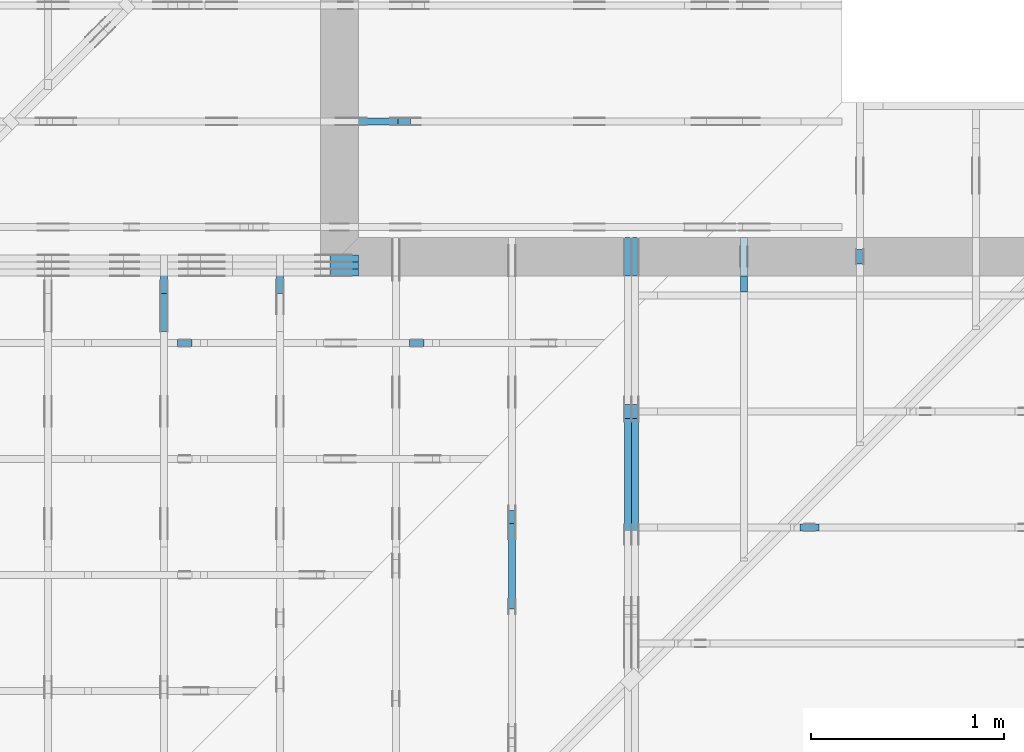
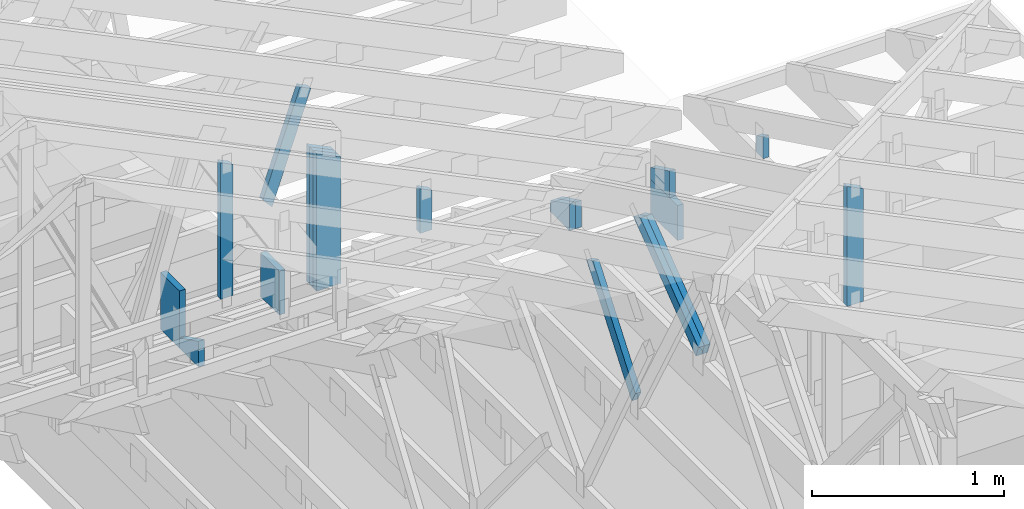
# One storey, part 50 of 159: 18 members, 10 elements without a shape of their own.
"""IFC2X3 building model written with IfcOpenShell, lengths in millimetres."""

from ifc_helpers import new_model, si_unit, frame, origin, origin_with_axes, origin_2d, place, context, project, spatial, faceted_brep, element, aggregate, save


model = new_model("IFC2X3")

# Units and contexts
model_context = context("Model", 3, precision=1e-05, world=origin())
plan_context = context("Plan", 2, precision=1e-05, world=origin_2d())
ifc_project = project(units=[si_unit("LENGTHUNIT", "METRE", prefix="MILLI"), si_unit("AREAUNIT", "SQUARE_METRE"), si_unit("VOLUMEUNIT", "CUBIC_METRE"), si_unit("SOLIDANGLEUNIT", "STERADIAN"), si_unit("PLANEANGLEUNIT", "RADIAN"), si_unit("MASSUNIT", "GRAM"), si_unit("TIMEUNIT", "SECOND"), si_unit("THERMODYNAMICTEMPERATUREUNIT", "DEGREE_CELSIUS"), si_unit("LUMINOUSINTENSITYUNIT", "LUMEN")], contexts=[model_context, plan_context])

# Site, building, storey
site_placement = place(None, origin_with_axes())
site = spatial("IfcSite", under=ifc_project, at=site_placement, CompositionType="ELEMENT")
building_placement = place(site_placement, origin_with_axes())
building = spatial("IfcBuilding", under=site, at=building_placement, Name="Plan 1", CompositionType="ELEMENT")
storey_placement = place(building_placement, origin_with_axes())
storey = spatial("IfcBuildingStorey", under=building, at=storey_placement, Name="Etasje 1", CompositionType="ELEMENT", Elevation=0.0)

# Assembly, members
assembly_1_placement = place(storey_placement, frame((10700.012663101485, 8801.999999990367, 0.0), z_axis=(0.0, -1.0, 6.123031769111886e-17), x_axis=(1.0, 0.0, 0.0)))
assembly_1 = element("IfcElementAssembly", 1, at=assembly_1_placement, inside=storey, Name="T8 (1)", AssemblyPlace="FACTORY", PredefinedType="TRUSS")
member_1_placement = place(assembly_1_placement, frame((5852.0, 1246.850830078125, -36.0), z_axis=(0.0, 0.0, 1.0), x_axis=(-1.836909530733566e-16, -1.0, 0.0)))
member_1 = element("IfcMember", 2, at=member_1_placement, Name="T8-S7", context=model_context, shape_type="Brep", body=[
    faceted_brep([(875.850830078125, 148.0, 36.0), (72.1844482421875, 148.0, 36.0), (0.0, 0.0, 36.0), (875.850830078125, 0.0, 36.0), (72.1844482421875, 148.0, 8.839753396454534e-15), (875.850830078125, 148.0, 1.0725724915142752e-13), (875.850830078125, 0.0, 1.0725724915142752e-13), (0.0, 0.0, 0.0), (2.2746622558770868e-05, 1.7741664121986508e-15, 2.4780981971831713e-31), (2.274662256075207e-05, 8.07867837839156e-16, 36.0), (72.18444585427645, 148.0, 36.0), (72.18444585427645, 148.0, -1.8327149350788936e-30), (875.8508300781257, -1.608858737271414e-13, 9.851093160326101e-30), (875.8508300781257, -1.5868158229026112e-13, 36.0), (2.2746622562408447e-05, 2.2042872585315014e-15, 36.0), (2.2746622562408447e-05, -4.178348777688724e-21, 2.5584162308217877e-37), (875.8508300781257, 148.0, 0.0), (875.8508300781257, 148.0, 36.0), (875.8508300781257, 0.0, 36.0), (875.8508300781257, 0.0, 0.0), (72.18444585427642, 148.0, 0.0), (72.18444585427642, 148.0, 36.0), (875.8508300781257, 147.99999999999994, 36.0), (875.8508300781257, 147.99999999999994, -3.1554436208840472e-30)], [[[0, 1, 2, 3]], [[4, 5, 6, 7]], [[8, 9, 10, 11]], [[12, 13, 14, 15]], [[16, 17, 18, 19]], [[20, 21, 22, 23]]]),
])
member_2_placement = place(assembly_1_placement, frame((5852.0, 1246.850830078125, -72.0), z_axis=(0.0, 0.0, 1.0), x_axis=(-1.836909530733566e-16, -1.0, 0.0)))
member_2 = element("IfcMember", 3, at=member_2_placement, Name="T8-S7", context=model_context, shape_type="Brep", body=[
    faceted_brep([(875.850830078125, 148.0, 36.0), (72.1844482421875, 148.0, 36.0), (0.0, 0.0, 36.0), (875.850830078125, 0.0, 36.0), (72.1844482421875, 148.0, 8.839753396454534e-15), (875.850830078125, 148.0, 1.0725724915142752e-13), (875.850830078125, 0.0, 1.0725724915142752e-13), (0.0, 0.0, 0.0), (2.2746622558770868e-05, 1.7741664121986508e-15, 2.4780981971831713e-31), (2.274662256075207e-05, 8.07867837839156e-16, 36.0), (72.18444585427645, 148.0, 36.0), (72.18444585427645, 148.0, -1.8327149350788936e-30), (875.8508300781257, -1.608858737271414e-13, 9.851093160326101e-30), (875.8508300781257, -1.5868158229026112e-13, 36.0), (2.2746622562408447e-05, 2.2042872585315014e-15, 36.0), (2.2746622562408447e-05, -4.178348777688724e-21, 2.5584162308217877e-37), (875.8508300781257, 148.0, 0.0), (875.8508300781257, 148.0, 36.0), (875.8508300781257, 0.0, 36.0), (875.8508300781257, 0.0, 0.0), (72.18444585427642, 148.0, 0.0), (72.18444585427642, 148.0, 36.0), (875.8508300781257, 147.99999999999994, 36.0), (875.8508300781257, 147.99999999999994, -3.1554436208840472e-30)], [[[0, 1, 2, 3]], [[4, 5, 6, 7]], [[8, 9, 10, 11]], [[12, 13, 14, 15]], [[16, 17, 18, 19]], [[20, 21, 22, 23]]]),
])
member_3_placement = place(assembly_1_placement, frame((5852.0, 1246.850830078125, -108.0), z_axis=(0.0, 0.0, 1.0), x_axis=(-1.836909530733566e-16, -1.0, 0.0)))
member_3 = element("IfcMember", 4, at=member_3_placement, Name="T8-S7", context=model_context, shape_type="Brep", body=[
    faceted_brep([(875.850830078125, 148.0, 36.0), (72.1844482421875, 148.0, 36.0), (0.0, 0.0, 36.0), (875.850830078125, 0.0, 36.0), (72.1844482421875, 148.0, 8.839753396454534e-15), (875.850830078125, 148.0, 1.0725724915142752e-13), (875.850830078125, 0.0, 1.0725724915142752e-13), (0.0, 0.0, 0.0), (2.2746622558770868e-05, 1.7741664121986508e-15, 2.4780981971831713e-31), (2.274662256075207e-05, 8.07867837839156e-16, 36.0), (72.18444585427645, 148.0, 36.0), (72.18444585427645, 148.0, -1.8327149350788936e-30), (875.8508300781257, -1.608858737271414e-13, 9.851093160326101e-30), (875.8508300781257, -1.5868158229026112e-13, 36.0), (2.2746622562408447e-05, 2.2042872585315014e-15, 36.0), (2.2746622562408447e-05, -4.178348777688724e-21, 2.5584162308217877e-37), (875.8508300781257, 148.0, 0.0), (875.8508300781257, 148.0, 36.0), (875.8508300781257, 0.0, 36.0), (875.8508300781257, 0.0, 0.0), (72.18444585427642, 148.0, 0.0), (72.18444585427642, 148.0, 36.0), (875.8508300781257, 147.99999999999994, 36.0), (875.8508300781257, 147.99999999999994, -3.1554436208840472e-30)], [[[0, 1, 2, 3]], [[4, 5, 6, 7]], [[8, 9, 10, 11]], [[12, 13, 14, 15]], [[16, 17, 18, 19]], [[20, 21, 22, 23]]]),
])
aggregate(assembly_1, [member_1, member_2, member_3])

# Assembly, member
assembly_2_placement = place(storey_placement, frame((19200.01266310149, 9617.999978540158, 1.1021457184401395e-15), z_axis=(1.2246063538223773e-16, 1.0, 6.123031769111886e-17), x_axis=(-1.0, 1.2246063538223773e-16, 0.0)))
assembly_2 = element("IfcElementAssembly", 5, at=assembly_2_placement, inside=storey, Name="V12 (104)", AssemblyPlace="FACTORY", PredefinedType="TRUSS")
member_4_placement = place(assembly_2_placement, frame((2228.9607302799177, 1052.1593241434744, -36.0), z_axis=(0.0, 0.0, 1.0), x_axis=(0.32803674405309335, -0.9446649641809763, 0.0)))
member_4 = element("IfcMember", 6, at=member_4_placement, Name="V12-D66", context=model_context, shape_type="Brep", body=[
    faceted_brep([(681.0706110310787, 72.99994068345177, 36.0), (8.410677298797964e-05, 72.99994068345177, 36.0), (8.769760310429888, 0.00011918098152818857, 36.0), (721.0591585070997, 0.00011918098152818857, 36.0), (8.410677298797964e-05, 72.99994068345177, 1.0299768860057616e-20), (681.0706110310787, 72.99994068345177, 8.340433976703478e-14), (721.0591585070997, 0.00011918098152818857, 8.83013626989611e-14), (8.769760310429888, 0.00011918098152818857, 1.0739504197651744e-15), (8.769783254570372, 2.2695207917422522e-05, 0.0), (8.769783254570376, 2.2695207917644566e-05, 36.0), (2.3092638912203256e-14, 73.00002269520702, 36.0), (2.1316282072803006e-14, 73.00002269520702, -1.3805065841367707e-30), (721.0591663880548, 2.2695208419800768e-05, -2.9164548988533967e-30), (721.0591663880548, 2.269520842200506e-05, 36.0), (8.76978325457037, 2.2695207920206116e-05, 36.0), (8.76978325457037, 2.2695207918001825e-05, -3.547096521402882e-32), (681.070651999221, 73.00002269520658, -5.4998942480018194e-30), (681.070651999221, 73.00002269520658, 36.0), (721.0591663880548, 2.2695208372169873e-05, 36.0), (721.0591663880548, 2.2695208372169873e-05, -5.243406304481854e-30), (0.0, 73.00002269520701, 0.0), (0.0, 73.00002269520701, 36.0), (681.0706519992211, 73.00002269520651, 36.0), (681.0706519992211, 73.00002269520651, -2.3665827156630354e-30)], [[[0, 1, 2, 3]], [[4, 5, 6, 7]], [[8, 9, 10, 11]], [[12, 13, 14, 15]], [[16, 17, 18, 19]], [[20, 21, 22, 23]]]),
])
aggregate(assembly_2, [member_4])

assembly_3_placement = place(storey_placement, frame((16311.022261404749, -699.9989301294839, 1.1021457184401395e-15), z_axis=(1.0, -6.123031769111886e-17, 6.123031769111886e-17), x_axis=(6.123031769111886e-17, 1.0, 0.0)))
assembly_3 = element("IfcElementAssembly", 7, at=assembly_3_placement, inside=storey, Name="V8 (33)", AssemblyPlace="FACTORY", PredefinedType="TRUSS")
member_5_placement = place(assembly_3_placement, frame((9609.9990234375, 370.9999999999935, -36.0), z_axis=(0.0, 0.0, 1.0), x_axis=(3.270178724167072e-14, 1.0, 0.0)))
member_5 = element("IfcMember", 8, at=member_5_placement, Name="V8-S3", context=model_context, shape_type="Brep", body=[
    faceted_brep([(278.47998046874994, 198.0000000000091, 36.0), (0.0, 198.0000000000091, 36.0), (6.480149750132114e-12, 0.0, 36.0), (278.4799804687564, 0.0, 36.0), (0.0, 198.0000000000091, 0.0), (278.47998046874994, 198.0000000000091, 3.410283534943627e-14), (278.4799804687564, 0.0, 3.4102835349437066e-14), (6.480149750132114e-12, 0.0, 7.935632557732277e-28), (6.480149790444615e-12, 9.332086483482271e-05, -2.4683472462447996e-36), (6.482354081881495e-12, 9.332086483482271e-05, 36.0), (8.773584851484226e-14, 198.00009332085028, 36.0), (8.553155707796198e-14, 198.00009332085028, -5.237124412499736e-30), (278.48000000045346, 9.331853113146364e-05, -3.676616062479308e-30), (278.48000000045346, 9.331853113366793e-05, 36.0), (6.480149750132132e-12, 9.3320864837027e-05, 36.0), (6.480149750132114e-12, 9.332086483482271e-05, 0.0), (278.48000000045346, 198.00009331853107, 3.9758589623138995e-28), (278.48000000045346, 198.00009331853107, 36.0), (278.48000000045346, 9.331853107141796e-05, 36.0), (278.48000000045346, 9.331853107141796e-05, 0.0), (0.0, 198.00009332085028, 0.0), (0.0, 198.00009332085028, 36.0), (278.480000000447, 198.00009331853107, 36.0), (278.480000000447, 198.00009331853107, 0.0)], [[[0, 1, 2, 3]], [[4, 5, 6, 7]], [[8, 9, 10, 11]], [[12, 13, 14, 15]], [[16, 17, 18, 19]], [[20, 21, 22, 23]]]),
])
aggregate(assembly_3, [member_5])

# Assembly, members
assembly_4_placement = place(storey_placement, frame((18074.541652722903, -699.9989301294845, 4.408582873760558e-15), z_axis=(-1.0, 1.836909530733566e-16, 6.123031769111886e-17), x_axis=(-1.836909530733566e-16, -1.0, 0.0)))
assembly_4 = element("IfcElementAssembly", 9, at=assembly_4_placement, inside=storey, Name="V5 (30)", AssemblyPlace="FACTORY", PredefinedType="TRUSS")
member_6_placement = place(assembly_4_placement, frame((-9501.998923972249, 222.99999999999997, -36.0), z_axis=(0.0, 0.0, 1.0), x_axis=(6.123031769111886e-17, 1.0, 0.0)))
member_6 = element("IfcMember", 10, at=member_6_placement, Name="V5-S4", context=model_context, shape_type="Brep", body=[
    faceted_brep([(73.74774169921878, 198.00009946525097, 36.0), (0.0, 198.00009946525097, 36.0), (2.842170943040401e-14, 9.94652509689331e-05, 36.0), (170.31878662109378, 9.94652509689331e-05, 36.0), (0.0, 198.00009946525097, 0.0), (73.74774169921878, 198.00009946525097, 9.03119530649148e-15), (170.31878662109378, 9.94652509689331e-05, 2.0857346827150914e-14), (2.842170943040401e-14, 9.94652509689331e-05, 3.4805405954966126e-30), (1.1937117960769683e-12, 0.0, 0.0), (1.1959160875138486e-12, -2.6993892992798474e-31, 36.0), (1.2201632933197599e-12, 198.00000000186265, 36.0), (1.2179590018828796e-12, 198.00000000186265, -1.4846641146178842e-30), (170.31878034491095, 1.8625988906436828e-09, 2.832427994748259e-30), (170.31878034491095, 1.8626010949351197e-09, 36.0), (1.1937117960769443e-12, 2.204291436879955e-15, 36.0), (1.1937117960769683e-12, -3.2421216959835216e-28, 1.9851614143888933e-44), (73.74772780854258, 198.00000000186265, -1.5777218104420236e-30), (73.74772780854258, 198.00000000186265, 36.0), (170.31878034491098, 1.8626593600856722e-09, 36.0), (170.31878034491098, 1.8626593600856722e-09, 0.0), (1.1937117960769683e-12, 198.00000000186265, 0.0), (1.1937117960769683e-12, 198.00000000186265, 36.0), (73.74772780854258, 198.00000000186265, 36.0), (73.74772780854258, 198.00000000186265, 0.0)], [[[0, 1, 2, 3]], [[4, 5, 6, 7]], [[8, 9, 10, 11]], [[12, 13, 14, 15]], [[16, 17, 18, 19]], [[20, 21, 22, 23]]]),
])
member_7_placement = place(assembly_4_placement, frame((-9501.998923972249, 222.99999999999997, -72.0), z_axis=(0.0, 0.0, 1.0), x_axis=(6.123031769111886e-17, 1.0, 0.0)))
member_7 = element("IfcMember", 11, at=member_7_placement, Name="V5-S4", context=model_context, shape_type="Brep", body=[
    faceted_brep([(73.74774169921878, 198.00009946525097, 36.0), (0.0, 198.00009946525097, 36.0), (2.842170943040401e-14, 9.94652509689331e-05, 36.0), (170.31878662109378, 9.94652509689331e-05, 36.0), (0.0, 198.00009946525097, 0.0), (73.74774169921878, 198.00009946525097, 9.03119530649148e-15), (170.31878662109378, 9.94652509689331e-05, 2.0857346827150914e-14), (2.842170943040401e-14, 9.94652509689331e-05, 3.4805405954966126e-30), (1.1937117960769683e-12, 0.0, 0.0), (1.1959160875138486e-12, -2.6993892992798474e-31, 36.0), (1.2201632933197599e-12, 198.00000000186265, 36.0), (1.2179590018828796e-12, 198.00000000186265, -1.4846641146178842e-30), (170.31878034491095, 1.8625988906436828e-09, 2.832427994748259e-30), (170.31878034491095, 1.8626010949351197e-09, 36.0), (1.1937117960769443e-12, 2.204291436879955e-15, 36.0), (1.1937117960769683e-12, -3.2421216959835216e-28, 1.9851614143888933e-44), (73.74772780854258, 198.00000000186265, -1.5777218104420236e-30), (73.74772780854258, 198.00000000186265, 36.0), (170.31878034491098, 1.8626593600856722e-09, 36.0), (170.31878034491098, 1.8626593600856722e-09, 0.0), (1.1937117960769683e-12, 198.00000000186265, 0.0), (1.1937117960769683e-12, 198.00000000186265, 36.0), (73.74772780854258, 198.00000000186265, 36.0), (73.74772780854258, 198.00000000186265, 0.0)], [[[0, 1, 2, 3]], [[4, 5, 6, 7]], [[8, 9, 10, 11]], [[12, 13, 14, 15]], [[16, 17, 18, 19]], [[20, 21, 22, 23]]]),
])
member_8_placement = place(assembly_4_placement, frame((-8837.338970727391, 717.4950314596726, -36.0), z_axis=(0.0, 0.0, 1.0), x_axis=(0.7964129491034229, -0.6047531847790376, 0.0)))
member_8 = element("IfcMember", 12, at=member_8_placement, Name="V5-D60", context=model_context, shape_type="Brep", body=[
    faceted_brep([(796.6997639617321, 73.00006327458777, 36.0), (36.85758525912206, 73.00006327458777, 36.0), (3.061633378820261e-05, 0.00013089083131490042, 36.0), (817.6807396894483, 0.00013089083131490042, 36.0), (36.85758525912206, 73.00006327458777, 4.5136033094870866e-15), (796.6997639617321, 73.00006327458777, 9.756435930363253e-14), (817.6807396894483, 0.00013089083131490042, 1.0013370292218797e-13), (3.061633378820261e-05, 0.00013089083131490042, 3.749295688777965e-21), (2.095722141833012e-15, 0.00013639759072142315, -1.4375035780612495e-31), (4.063433888413376e-15, 0.00013639759072042967, 36.0), (36.85723078302818, 73.00013639759162, 36.0), (36.85723078302818, 73.00013639759162, -7.358978317503628e-31), (817.68091931447, 0.00013639758548855484, 4.203172982901901e-29), (817.68091931447, 0.00013639758549075914, 36.0), (1.4109555365575329e-29, 0.00013639759072468555, 36.0), (0.0, 0.00013639759072248125, 0.0), (796.6998592314928, 73.00013639758708, -1.262177448353619e-29), (796.6998592314928, 73.00013639758708, 36.0), (817.6809193144697, 0.00013639758614658604, 36.0), (817.6809193144697, 0.00013639758614658604, -1.262177448353619e-29), (36.85723078302817, 73.00013639759163, 0.0), (36.85723078302817, 73.00013639759163, 36.0), (796.6998592314931, 73.00013639758703, 36.0), (796.6998592314931, 73.00013639758703, -3.944304526105059e-30)], [[[0, 1, 2, 3]], [[4, 5, 6, 7]], [[8, 9, 10, 11]], [[12, 13, 14, 15]], [[16, 17, 18, 19]], [[20, 21, 22, 23]]]),
])
member_9_placement = place(assembly_4_placement, frame((-8837.338970727391, 717.4950314596726, -72.0), z_axis=(0.0, 0.0, 1.0), x_axis=(0.7964129491034229, -0.6047531847790376, 0.0)))
member_9 = element("IfcMember", 13, at=member_9_placement, Name="V5-D60", context=model_context, shape_type="Brep", body=[
    faceted_brep([(796.6997639617321, 73.00006327458777, 36.0), (36.85758525912206, 73.00006327458777, 36.0), (3.061633378820261e-05, 0.00013089083131490042, 36.0), (817.6807396894483, 0.00013089083131490042, 36.0), (36.85758525912206, 73.00006327458777, 4.5136033094870866e-15), (796.6997639617321, 73.00006327458777, 9.756435930363253e-14), (817.6807396894483, 0.00013089083131490042, 1.0013370292218797e-13), (3.061633378820261e-05, 0.00013089083131490042, 3.749295688777965e-21), (2.095722141833012e-15, 0.00013639759072142315, -1.4375035780612495e-31), (4.063433888413376e-15, 0.00013639759072042967, 36.0), (36.85723078302818, 73.00013639759162, 36.0), (36.85723078302818, 73.00013639759162, -7.358978317503628e-31), (817.68091931447, 0.00013639758548855484, 4.203172982901901e-29), (817.68091931447, 0.00013639758549075914, 36.0), (1.4109555365575329e-29, 0.00013639759072468555, 36.0), (0.0, 0.00013639759072248125, 0.0), (796.6998592314928, 73.00013639758708, -1.262177448353619e-29), (796.6998592314928, 73.00013639758708, 36.0), (817.6809193144697, 0.00013639758614658604, 36.0), (817.6809193144697, 0.00013639758614658604, -1.262177448353619e-29), (36.85723078302817, 73.00013639759163, 0.0), (36.85723078302817, 73.00013639759163, 36.0), (796.6998592314931, 73.00013639758703, 36.0), (796.6998592314931, 73.00013639758703, -3.944304526105059e-30)], [[[0, 1, 2, 3]], [[4, 5, 6, 7]], [[8, 9, 10, 11]], [[12, 13, 14, 15]], [[16, 17, 18, 19]], [[20, 21, 22, 23]]]),
])
aggregate(assembly_4, [member_6, member_7, member_8, member_9])

# Assembly, member
assembly_5_placement = place(storey_placement, frame((17475.02226140475, -699.9989301294827, 1.1021457184401395e-15), z_axis=(-1.0, 1.836909530733566e-16, 6.123031769111886e-17), x_axis=(-1.836909530733566e-16, -1.0, 0.0)))
assembly_5 = element("IfcElementAssembly", 14, at=assembly_5_placement, inside=storey, Name="V6 (31)", AssemblyPlace="FACTORY", PredefinedType="TRUSS")
member_10_placement = place(assembly_5_placement, frame((-8287.689453125002, 985.5772705078125, -36.0), z_axis=(0.0, 0.0, 1.0), x_axis=(0.6077192601701953, -0.7941519381190167, 0.0)))
member_10 = element("IfcMember", 15, at=member_10_placement, Name="V6-D62", context=model_context, shape_type="Brep", body=[
    faceted_brep([(742.2078949296147, 73.00027635544029, 36.0), (14.75236930580104, 73.00027635544029, 36.0), (0.0, 0.0, 36.0), (773.8788700743089, 0.0, 36.0), (14.75236930580104, 73.00027635544029, 1.8065845185818165e-15), (742.2078949296147, 73.00027635544029, 9.089125039879376e-14), (773.8788700743089, 0.0, 9.476969813818806e-14), (0.0, 0.0, 0.0), (0.00022540169811499373, 0.00025948535494574223, 1.198048796030385e-31), (0.00022540169811715436, 0.0002594853549453056, 36.0), (14.752456127954233, 73.00025948535314, 36.0), (14.75245612795423, 73.00025948535314, 1.05511620613424e-30), (773.8788998711179, 0.00025948535549054233, 2.2306635200299982e-29), (773.8788998711179, 0.0002594853554927466, 36.0), (0.0002254016981169116, 0.0002594853549475588, 36.0), (0.0002254016981169116, 0.0002594853549453545, 9.027796614315168e-36), (742.2078817748177, 73.00025948535395, -1.1917857587796813e-29), (742.2078817748177, 73.00025948535395, 36.0), (773.8788998711177, 0.0002594853557980059, 36.0), (773.8788998711177, 0.0002594853557980059, -1.1672650650887484e-29), (14.752456127954247, 73.00025948535313, 0.0), (14.752456127954247, 73.00025948535313, 36.0), (742.2078817748179, 73.00025948535405, 36.0), (742.2078817748179, 73.00025948535405, 7.888609052210118e-31)], [[[0, 1, 2, 3]], [[4, 5, 6, 7]], [[8, 9, 10, 11]], [[12, 13, 14, 15]], [[16, 17, 18, 19]], [[20, 21, 22, 23]]]),
])
aggregate(assembly_5, [member_10])

assembly_6_placement = place(storey_placement, frame((19275.02226140475, 9699.999999999993, 1.1021457184401395e-15), z_axis=(-1.0, 1.836909530733566e-16, 6.123031769111886e-17), x_axis=(-1.836909530733566e-16, -1.0, 0.0)))
assembly_6 = element("IfcElementAssembly", 16, at=assembly_6_placement, inside=storey, Name="S23 (56)", AssemblyPlace="FACTORY", PredefinedType="TRUSS")
member_11_placement = place(assembly_6_placement, frame((762.5, 362.835490555932, -36.0), z_axis=(0.0, 0.0, 1.0), x_axis=(-1.836909530733566e-16, -1.0, 0.0)))
member_11 = element("IfcMember", 17, at=member_11_placement, Name="S23-D72", context=model_context, shape_type="Brep", body=[
    faceted_brep([(139.83549055593195, 73.00000000000011, 36.0), (1.0819603801337507e-05, 73.00000000000011, 36.0), (35.60447248952573, 0.0, 36.0), (139.83549055593195, 0.0, 36.0), (1.0819603801337507e-05, 73.00000000000011, 1.3249755560958657e-21), (139.83549055593195, 73.00000000000011, 1.712434302246633e-14), (139.83549055593195, 0.0, 1.712434302246633e-14), (35.60447248952573, 0.0, 4.360146323516725e-15), (35.60447896533474, -1.7763568394002505e-15, 3.4633466240401087e-31), (35.60447896533475, 0.0, 36.0), (3.552713678800501e-15, 73.00000000000001, 36.0), (0.0, 73.00000000000001, -1.922479744743257e-31), (139.83549055593195, 5.967783702884803e-14, 3.3069882705980434e-30), (139.83549055593195, 6.188212846572831e-14, 36.0), (35.60447896533475, -1.1547312833676879e-14, 36.0), (35.60447896533475, -1.3751604270557158e-14, 8.420150982487615e-31), (139.83549055593195, 73.00000000000011, 0.0), (139.83549055593195, 73.00000000000011, 36.0), (139.83549055593195, 1.1368683772161603e-13, 36.0), (139.83549055593195, 1.1368683772161603e-13, 0.0), (0.0, 73.0, 0.0), (0.0, 73.0, 36.0), (139.83549055593195, 73.00000000000014, 36.0), (139.83549055593195, 73.00000000000014, 1.5777218104420236e-30)], [[[0, 1, 2, 3]], [[4, 5, 6, 7]], [[8, 9, 10, 11]], [[12, 13, 14, 15]], [[16, 17, 18, 19]], [[20, 21, 22, 23]]]),
])
aggregate(assembly_6, [member_11])

# Assembly, members
assembly_7_placement = place(storey_placement, frame((18675.02226140475, 8999.999999999993, 1.1021457184401395e-15), z_axis=(-1.0, 1.836909530733566e-16, 6.123031769111886e-17), x_axis=(-1.836909530733566e-16, -1.0, 0.0)))
assembly_7 = element("IfcElementAssembly", 18, at=assembly_7_placement, inside=storey, Name="S25 (55)", AssemblyPlace="FACTORY", PredefinedType="TRUSS")
member_12_placement = place(assembly_7_placement, frame((198.00000000186265, 222.9999999999992, -36.0), z_axis=(0.0, 0.0, 1.0), x_axis=(6.123031769111886e-17, 1.0, 0.0)))
member_12 = element("IfcMember", 19, at=member_12_placement, Name="S25-S4", context=model_context, shape_type="Brep", body=[
    faceted_brep([(73.74771118164142, 198.00000000186267, 36.0), (7.958078640513122e-13, 198.00000000186267, 36.0), (7.958078640513122e-13, 1.862645149230957e-09, 36.0), (170.31878662109455, 1.862645149230957e-09, 36.0), (7.958078640513122e-13, 198.00000000186267, 9.745513667390515e-29), (73.74771118164142, 198.00000000186267, 9.031191569289567e-15), (170.31878662109455, 1.862645149230957e-09, 2.085734682715101e-14), (7.958078640513122e-13, 1.862645149230957e-09, 9.745513667390515e-29), (0.0, 0.0, 0.0), (2.204291436880279e-15, -9.080057312278785e-30, 36.0), (8.178184691953749e-13, 198.0, 36.0), (8.156141777584947e-13, 198.0, 5.275234171675631e-31), (170.31877734232773, 1.8627501312700795e-09, -4.687813309593267e-30), (170.31877734232773, 1.8627523355615164e-09, 36.0), (-2.4107994593886833e-26, 2.204291436880279e-15, 36.0), (0.0, 0.0, 0.0), (73.7477248059594, 198.0000000018627, 1.5777218104420236e-30), (73.7477248059594, 198.0000000018627, 36.0), (170.3187773423278, 1.8626877817951026e-09, 36.0), (170.3187773423278, 1.8626877817951026e-09, 3.1554436208840472e-30), (8.242295734817162e-13, 198.0, 0.0), (8.242295734817162e-13, 198.0, 36.0), (73.74772480595936, 198.00000000186267, 36.0), (73.74772480595936, 198.00000000186267, 0.0)], [[[0, 1, 2, 3]], [[4, 5, 6, 7]], [[8, 9, 10, 11]], [[12, 13, 14, 15]], [[16, 17, 18, 19]], [[20, 21, 22, 23]]]),
])
member_13_placement = place(assembly_7_placement, frame((282.00633155073683, 223.0, -36.0), z_axis=(0.0, 0.0, 1.0), x_axis=(-1.0, 4.119263524032801e-15, 0.0)))
member_13 = element("IfcMember", 20, at=member_13_placement, Name="S25-U31", context=model_context, shape_type="Brep", body=[
    faceted_brep([(282.0063315507359, 223.00000000000117, 36.0), (1.4412064047064632e-05, 223.00000000000117, 36.0), (1.4412064956559334e-05, 0.0, 36.0), (282.00633155073683, 0.0, 36.0), (1.4412064047064632e-05, 223.00000000000117, 1.7649105203730393e-21), (282.0063315507359, 223.00000000000117, 3.4534674543517114e-14), (282.00633155073683, 0.0, 3.453467454351723e-14), (1.4412064956559334e-05, 0.0, 1.7649106317503384e-21), (9.094947017729282e-13, 0.0, 0.0), (9.116989932098085e-13, 8.540179452422816e-30, 36.0), (4.772067073097186e-14, 223.0, 36.0), (4.551637929409158e-14, 223.0, -2.786982364326692e-30), (282.00633155073683, 1.2005576776955354e-12, -2.159445804128965e-30), (282.00633155073683, 1.2027619691324157e-12, 36.0), (9.094947017729282e-13, 2.2042914368803927e-15, 36.0), (9.094947017729282e-13, 1.1374101789470858e-28, -6.964398660204246e-45), (282.00633155073683, 223.00000000000117, 5.679798517591285e-29), (282.00633155073683, 223.00000000000117, 36.0), (282.00633155073683, 1.1652900866465643e-12, 36.0), (282.00633155073683, 1.1652900866465643e-12, 0.0), (0.0, 223.0, 0.0), (0.0, 223.0, 36.0), (282.0063315507359, 223.00000000000117, 36.0), (282.0063315507359, 223.00000000000117, 1.5777218104420236e-30)], [[[0, 1, 2, 3]], [[4, 5, 6, 7]], [[8, 9, 10, 11]], [[12, 13, 14, 15]], [[16, 17, 18, 19]], [[20, 21, 22, 23]]]),
])
aggregate(assembly_7, [member_12, member_13])

# Assembly, member
assembly_8_placement = place(storey_placement, frame((21100.012663101486, 7517.993668449257, 1.1021457184401395e-15), z_axis=(1.2246063538223773e-16, 1.0, 6.123031769111886e-17), x_axis=(-1.0, 1.2246063538223773e-16, 0.0)))
assembly_8 = element("IfcElementAssembly", 21, at=assembly_8_placement, inside=storey, Name="S18 (46)", AssemblyPlace="FACTORY", PredefinedType="TRUSS")
member_14_placement = place(assembly_8_placement, frame((2019.0946044921875, 987.9109634286215, -36.0), z_axis=(0.0, 0.0, 1.0), x_axis=(-1.836909530733566e-16, -1.0, 0.0)))
member_14 = element("IfcMember", 22, at=member_14_placement, Name="S18-S11", context=model_context, shape_type="Brep", body=[
    faceted_brep([(764.9109634286215, 98.00012207031273, 36.0), (1.3721590221393853e-05, 98.00012207031273, 36.0), (47.79780424893397, 0.0, 36.0), (764.9109634286215, 0.0, 36.0), (1.3721590221393853e-05, 98.00012207031273, 1.6803546569665913e-21), (764.9109634286215, 98.00012207031273, 9.367148259230859e-14), (764.9109634286215, 0.0, 9.367148259230859e-14), (47.79780424893397, 0.0, 5.8533494782002766e-15), (47.797793679405, 3.8814963776445666e-05, -3.944304526105059e-31), (47.797793679405004, 3.8814963776445666e-05, 36.0), (2.1316282072803006e-14, 98.00003881496401, 36.0), (2.1316282072803006e-14, 98.00003881496401, -1.9721522630525295e-30), (764.9109634292258, 3.881496361723058e-05, 2.3453419277097786e-29), (764.9109634292258, 3.881496361943487e-05, 36.0), (47.797793679405004, 3.8814963751162064e-05, 36.0), (47.797793679405004, 3.881496374895777e-05, 1.4655582083566184e-30), (764.9109634292258, 98.000038814964, 3.74235613436848e-27), (764.9109634292258, 98.000038814964, 36.0), (764.9109634292258, 3.881496400026663e-05, 36.0), (764.9109634292258, 3.881496400026663e-05, 0.0), (0.0, 98.000038814964, 0.0), (-1.3496946496399237e-31, 98.000038814964, 36.0), (764.9109634291648, 98.00003881496396, 36.0), (764.9109634291648, 98.00003881496396, -3.1554436208840472e-30)], [[[0, 1, 2, 3]], [[4, 5, 6, 7]], [[8, 9, 10, 11]], [[12, 13, 14, 15]], [[16, 17, 18, 19]], [[20, 21, 22, 23]]]),
])
aggregate(assembly_8, [member_14])

# Assembly, members
assembly_9_placement = place(storey_placement, frame((11246.01259527543, 8436.00006782605, 727.7147722720857), z_axis=(0.0, -1.0, 6.123031769111886e-17), x_axis=(1.0, 0.0, 0.0)))
assembly_9 = element("IfcElementAssembly", 23, at=assembly_9_placement, inside=storey, Name="Tr1 (1)", AssemblyPlace="FACTORY", PredefinedType="TRUSS")
member_15_placement = place(assembly_9_placement, frame((4590.500067826054, 89.22082903113537, -36.0), z_axis=(0.0, 0.0, 1.0), x_axis=(6.123031769111886e-17, 1.0, 0.0)))
member_15 = element("IfcMember", 24, at=member_15_placement, Name="Tr1-D58", context=model_context, shape_type="Brep", body=[
    faceted_brep([(870.1224326876146, 73.00006782605396, 36.0), (3.793571650589911e-06, 73.00006782605396, 36.0), (3.7935716648007656e-06, 6.782605396438157e-05, 36.0), (834.5179405001146, 6.782605396438157e-05, 36.0), (3.793571650589911e-06, 73.00006782605396, 4.645631946992848e-22), (870.1224326876146, 73.00006782605396, 1.0655574596726366e-13), (834.5179405001146, 6.782605396438157e-05, 1.0219559723152049e-13), (3.7935716648007656e-06, 6.782605396438157e-05, 4.645631964395551e-22), (1.0729195309977514e-11, 1.8367099231598242e-40, -8.96831017167883e-44), (1.0731399601414395e-11, 3.2374663713226847e-28, 36.0), (9.81165019023506e-15, 73.0, 36.0), (7.607358753354782e-15, 73.0, -4.65800993258218e-31), (834.5179701715656, -1.5329340129765785e-13, 9.386203661407763e-30), (834.5179701715656, -1.5108910986077757e-13, 36.0), (1.0729195309977513e-11, 2.204291436878308e-15, 36.0), (1.0729195309977513e-11, -1.970856112199957e-27, 1.2067614587348676e-43), (870.1224491368732, 73.00000000000006, -7.688461917283971e-30), (870.1224491368732, 73.00000000000006, 36.0), (834.5179701715656, 0.0, 36.0), (834.5179701715656, 0.0, -7.438183648941331e-30), (0.0, 73.0, 0.0), (-1.3496946496399237e-31, 73.0, 36.0), (870.1224491368731, 72.99999999999994, 36.0), (870.1224491368731, 72.99999999999994, -3.1554436208840472e-30)], [[[0, 1, 2, 3]], [[4, 5, 6, 7]], [[8, 9, 10, 11]], [[12, 13, 14, 15]], [[16, 17, 18, 19]], [[20, 21, 22, 23]]]),
])
member_16_placement = place(assembly_9_placement, frame((5790.500067826054, 89.2208290313116, -36.0), z_axis=(0.0, 0.0, 1.0), x_axis=(6.123031769111886e-17, 1.0, 0.0)))
member_16 = element("IfcMember", 25, at=member_16_placement, Name="Tr1-D71", context=model_context, shape_type="Brep", body=[
    faceted_brep([(284.84334943548527, 73.00006782605396, 36.0), (3.7933954359914424e-06, 73.00006782605396, 36.0), (3.7933954359914424e-06, 6.782605396438157e-05, 36.0), (249.23885724798527, 6.782605396438157e-05, 36.0), (3.7933954359914424e-06, 73.00006782605396, 4.645416153475927e-22), (284.84334943548527, 73.00006782605396, 3.488209755627429e-14), (249.23885724798527, 6.782605396438157e-05, 3.052194882053112e-14), (3.7933954359914424e-06, 6.782605396438157e-05, 4.645416153475927e-22), (1.0714984455262312e-11, 1.8367099231598242e-40, -8.96831017167883e-44), (1.0717188746699193e-11, 3.2276773508978505e-28, 36.0), (2.8019307794087628e-14, 73.0, 36.0), (2.581501635720735e-14, 73.0, -1.5806616527532267e-30), (249.23886389236247, -4.578292445130867e-14, 2.803303008982123e-30), (249.23886389236247, -4.357863301442839e-14, 36.0), (1.071498445526231e-11, 2.204291436878311e-15, 36.0), (1.071498445526231e-11, -1.9682457067533344e-27, 1.2051630991868744e-43), (284.84334285766994, 72.99999999999999, 6.897846187862988e-30), (284.84334285766994, 72.99999999999999, 36.0), (249.2388638923625, -1.4210854715202004e-14, 36.0), (249.2388638923625, -1.4210854715202004e-14, 3.492124298636302e-30), (0.0, 73.0, 0.0), (-1.3496946496399237e-31, 73.0, 36.0), (284.8433428576699, 72.99999999999999, 36.0), (284.8433428576699, 72.99999999999999, -7.888609052210118e-31)], [[[0, 1, 2, 3]], [[4, 5, 6, 7]], [[8, 9, 10, 11]], [[12, 13, 14, 15]], [[16, 17, 18, 19]], [[20, 21, 22, 23]]]),
])
aggregate(assembly_9, [member_15, member_16])

assembly_10_placement = place(storey_placement, frame((15675.02226140475, -699.9989301294845, 1.1021457184401395e-15), z_axis=(-1.0, 1.836909530733566e-16, 6.123031769111886e-17), x_axis=(-1.836909530733566e-16, -1.0, 0.0)))
assembly_10 = element("IfcElementAssembly", 26, at=assembly_10_placement, inside=storey, Name="T7 (111)", AssemblyPlace="FACTORY", PredefinedType="TRUSS")
member_17_placement = place(assembly_10_placement, frame((-9411.99893013318, 371.0, -36.0), z_axis=(0.0, 0.0, 1.0), x_axis=(-2.6074085653169515e-12, 1.0, 0.0)))
member_17 = element("IfcMember", 27, at=member_17_placement, Name="T7-S1", context=model_context, shape_type="Brep", body=[
    faceted_brep([(363.47723388723495, 198.0000933033716, 36.0), (5.162519300938584e-10, 198.0000933033716, 36.0), (0.0, 9.330431930720806e-05, 36.0), (363.4772338867187, 9.330431930720806e-05, 36.0), (5.162519300938584e-10, 198.0000933033716, 6.322053937660047e-26), (363.47723388723495, 198.0000933033716, 4.4511653008809024e-14), (363.4772338867187, 9.330431930720806e-05, 4.45116530087458e-14), (0.0, 9.330431930720806e-05, 0.0), (0.0, 0.0, 0.0), (2.204291436880279e-15, -5.7474038303501e-27, 36.0), (5.162615062011267e-10, 198.0, 36.0), (5.162593019096898e-10, 198.0, -4.513786253158592e-31), (363.47721516495375, 6.308078123434283e-08, -2.921223515766118e-30), (363.47721516495375, 6.308078343863427e-08, 36.0), (-3.825505976859566e-25, 2.204291436880279e-15, 36.0), (0.0, 0.0, 0.0), (363.47721516495375, 198.0000000612181, -3.16080787503955e-26), (363.47721516495375, 198.0000000612181, 36.0), (363.47721516495375, 6.308073352556676e-08, 36.0), (363.47721516495375, 6.308073352556676e-08, 0.0), (5.162519300938584e-10, 198.0, 0.0), (5.162519300938584e-10, 198.0, 36.0), (363.47721516547, 198.0000000612181, 36.0), (363.47721516547, 198.0000000612181, -1.5777218104420236e-30)], [[[0, 1, 2, 3]], [[4, 5, 6, 7]], [[8, 9, 10, 11]], [[12, 13, 14, 15]], [[16, 17, 18, 19]], [[20, 21, 22, 23]]]),
])
member_18_placement = place(assembly_10_placement, frame((-9213.998930133188, 371.0, -36.0), z_axis=(0.0, 0.0, 1.0), x_axis=(-1.7615569541788202e-10, 1.0, 0.0)))
member_18 = element("IfcMember", 28, at=member_18_placement, Name="T7-S5", context=model_context, shape_type="Brep", body=[
    faceted_brep([(66.21466067941009, 198.00009329264867, 36.0), (3.4878837595897494e-08, 198.00009329264867, 36.0), (0.0, 9.330431203125045e-05, 36.0), (162.7857055664063, 9.330431203125045e-05, 36.0), (3.4878837595897494e-08, 198.00009329264867, 4.271284613387488e-24), (66.21466067941009, 198.00009329264867, 8.108689418419832e-15), (162.7857055664063, 9.330431203125045e-05, 1.9934840934807988e-14), (0.0, 9.330431203125045e-05, 0.0), (-2.605355528885784e-24, 6.255140760913491e-08, 1.5952674669991638e-40), (2.2042914342749235e-15, 6.255140760913491e-08, 36.0), (3.487882230300644e-08, 198.00000006253686, 36.0), (3.4878820098715006e-08, 198.00000006253686, 1.071358042460672e-30), (162.78571493316844, -3.9667248731015275e-14, 2.4288382424236155e-30), (162.78571493316844, -3.7462957294134996e-14, 36.0), (8.470130163630552e-25, 6.255140981342635e-08, 36.0), (0.0, 6.255140760913491e-08, 0.0), (66.21466011511593, 198.0, 0.0), (66.21466011511593, 198.0, 36.0), (162.78571493316844, 1.4210854715202004e-14, 36.0), (162.78571493316846, 1.4210854715202004e-14, 1.5777218104420236e-30), (3.4878837595897494e-08, 198.00000006253686, 0.0), (3.4878837595897494e-08, 198.00000006253686, 36.0), (66.21466011511592, 198.0, 36.0), (66.21466011511592, 198.0, 0.0)], [[[0, 1, 2, 3]], [[4, 5, 6, 7]], [[8, 9, 10, 11]], [[12, 13, 14, 15]], [[16, 17, 18, 19]], [[20, 21, 22, 23]]]),
])
aggregate(assembly_10, [member_17, member_18])

save(model, "model.ifc")
